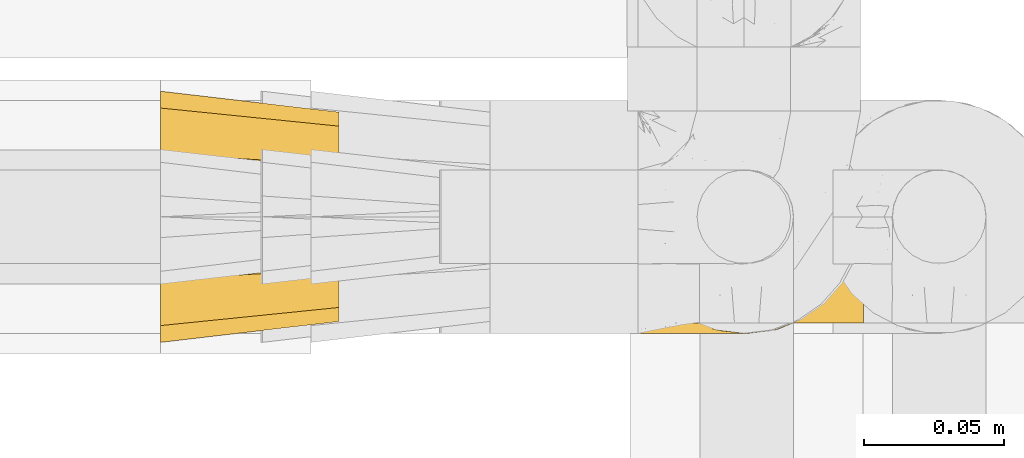
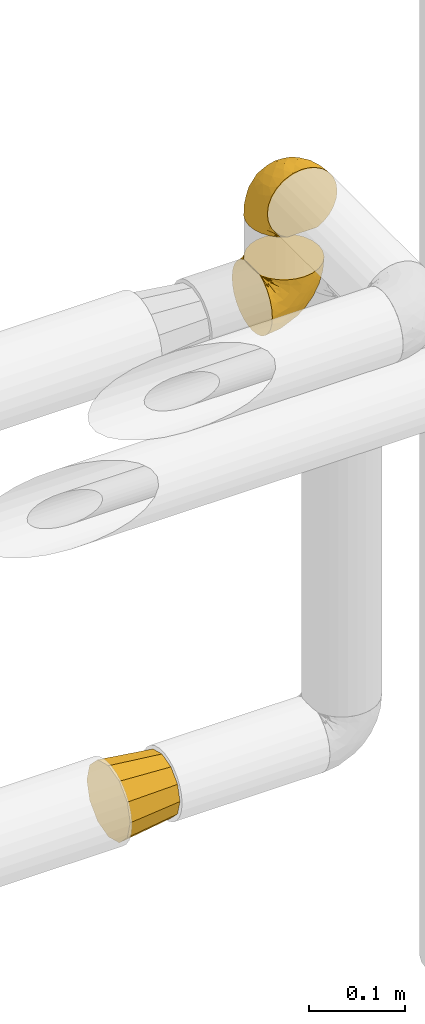
# One storey, part 458 of 827: 3 coverings.
"""IFC2X3 building model written with IfcOpenShell, lengths in millimetres."""

from ifc_helpers import new_model, entity, si_unit, converted_unit, derived_unit, direction, frame, origin, place, context, subcontext, project, spatial, faceted_brep, element, save


model = new_model("IFC2X3")

# Units and contexts
model_context = context("Model", 3, precision=0.01, world=origin(), true_north=direction((6.12303176911189e-17, 1.0)))
body_context = subcontext(model_context, "Body", "Model", "MODEL_VIEW")
ifc_project = project(units=[si_unit("LENGTHUNIT", "METRE", prefix="MILLI"), si_unit("AREAUNIT", "SQUARE_METRE"), si_unit("VOLUMEUNIT", "CUBIC_METRE"), converted_unit("PLANEANGLEUNIT", "DEGREE", entity("IfcRatioMeasure", 0.0174532925199433), si_unit("PLANEANGLEUNIT", "RADIAN"), dimensions=[0, 0, 0, 0, 0, 0, 0]), si_unit("MASSUNIT", "GRAM", prefix="KILO"), derived_unit("MASSDENSITYUNIT", [(si_unit("MASSUNIT", "GRAM", prefix="KILO"), 1), (si_unit("LENGTHUNIT", "METRE"), -3)]), derived_unit("MOMENTOFINERTIAUNIT", [(si_unit("LENGTHUNIT", "METRE"), 4)]), si_unit("TIMEUNIT", "SECOND"), si_unit("FREQUENCYUNIT", "HERTZ"), si_unit("THERMODYNAMICTEMPERATUREUNIT", "DEGREE_CELSIUS"), derived_unit("THERMALTRANSMITTANCEUNIT", [(si_unit("MASSUNIT", "GRAM", prefix="KILO"), 1), (si_unit("THERMODYNAMICTEMPERATUREUNIT", "KELVIN"), -1), (si_unit("TIMEUNIT", "SECOND"), -3)]), derived_unit("VOLUMETRICFLOWRATEUNIT", [(si_unit("LENGTHUNIT", "METRE"), 3), (si_unit("TIMEUNIT", "SECOND"), -1)]), derived_unit("MASSFLOWRATEUNIT", [(si_unit("MASSUNIT", "GRAM", prefix="KILO"), 1), (si_unit("TIMEUNIT", "SECOND"), -1)]), derived_unit("ROTATIONALFREQUENCYUNIT", [(si_unit("TIMEUNIT", "SECOND"), -1)]), si_unit("ELECTRICCURRENTUNIT", "AMPERE"), si_unit("ELECTRICVOLTAGEUNIT", "VOLT"), si_unit("POWERUNIT", "WATT"), si_unit("FORCEUNIT", "NEWTON", prefix="KILO"), si_unit("ILLUMINANCEUNIT", "LUX"), si_unit("LUMINOUSFLUXUNIT", "LUMEN"), si_unit("LUMINOUSINTENSITYUNIT", "CANDELA"), derived_unit("USERDEFINED", [(si_unit("MASSUNIT", "GRAM", prefix="KILO"), -1), (si_unit("LENGTHUNIT", "METRE"), -2), (si_unit("TIMEUNIT", "SECOND"), 3), (si_unit("LUMINOUSFLUXUNIT", "LUMEN"), 1)]), derived_unit("LINEARVELOCITYUNIT", [(si_unit("LENGTHUNIT", "METRE"), 1), (si_unit("TIMEUNIT", "SECOND"), -1)]), si_unit("PRESSUREUNIT", "PASCAL"), derived_unit("USERDEFINED", [(si_unit("LENGTHUNIT", "METRE"), -2), (si_unit("MASSUNIT", "GRAM", prefix="KILO"), 1), (si_unit("TIMEUNIT", "SECOND"), -2)]), derived_unit("LINEARFORCEUNIT", [(si_unit("MASSUNIT", "GRAM", prefix="KILO"), 1), (si_unit("LENGTHUNIT", "METRE"), 1), (si_unit("TIMEUNIT", "SECOND"), -2), (si_unit("LENGTHUNIT", "METRE"), -1)]), derived_unit("PLANARFORCEUNIT", [(si_unit("MASSUNIT", "GRAM", prefix="KILO"), 1), (si_unit("LENGTHUNIT", "METRE"), 1), (si_unit("TIMEUNIT", "SECOND"), -2), (si_unit("LENGTHUNIT", "METRE"), -2)])], contexts=[model_context])

# Site, building, storey
site_placement = place(None, origin())
site = spatial("IfcSite", under=ifc_project, at=site_placement, CompositionType="ELEMENT")
building_placement = place(site_placement, origin())
building = spatial("IfcBuilding", under=site, at=building_placement, CompositionType="ELEMENT")
storey_placement = place(building_placement, frame((0.0, 0.0, 28200.0)))
storey = spatial("IfcBuildingStorey", under=building, at=storey_placement, Name="08", CompositionType="ELEMENT", Elevation=28200.0)

# Coverings
covering_1_placement = place(storey_placement, frame((56354.23, 17453.4, 745.9)))
element("IfcCovering", 1, at=covering_1_placement, inside=storey, Name=":ADSK_", ObjectType=":ADSK_", PredefinedType="INSULATION", context=body_context, shape_type="Brep", body=[
    faceted_brep([(64.0, 9.1, 46.6), (64.0, 11.61, 37.22), (64.0, 14.12, 27.85), (64.0, 20.98, 20.98), (64.0, 27.85, 14.12), (64.0, 37.22, 11.61), (64.0, 46.6, 9.1), (64.0, 55.97, 11.61), (64.0, 65.35, 14.12), (64.0, 72.21, 20.98), (64.0, 79.07, 27.85), (64.0, 81.58, 37.22), (64.0, 84.1, 46.6), (64.0, 81.58, 55.97), (64.0, 79.07, 65.35), (64.0, 72.21, 72.21), (64.0, 65.35, 79.07), (64.0, 55.97, 81.58), (64.0, 46.6, 84.1), (64.0, 37.22, 81.58), (64.0, 27.85, 79.07), (64.0, 20.98, 72.21), (64.0, 14.12, 65.35), (64.0, 11.61, 55.97), (0.0, 77.33, 77.33), (0.0, 85.57, 69.1), (0.0, 88.1, 59.65), (0.0, 91.6, 46.6), (0.0, 88.1, 33.54), (0.0, 85.57, 24.1), (0.0, 77.33, 15.86), (0.0, 69.1, 7.62), (0.0, 59.65, 5.09), (0.0, 46.6, 1.6), (0.0, 33.54, 5.09), (0.0, 24.1, 7.62), (0.0, 15.86, 15.86), (0.0, 7.62, 24.1), (0.0, 5.09, 33.54), (0.0, 1.6, 46.6), (0.0, 5.09, 59.65), (0.0, 7.62, 69.1), (0.0, 15.86, 77.33), (0.0, 24.1, 85.57), (0.0, 33.54, 88.1), (0.0, 46.6, 91.6), (0.0, 59.65, 88.1), (0.0, 69.1, 85.57)], [[[0, 1, 2, 3, 4, 5, 6, 7, 8, 9, 10, 11, 12, 13, 14, 15, 16, 17, 18, 19, 20, 21, 22, 23]], [[24, 25, 26, 27, 28, 29, 30, 31, 32, 33, 34, 35, 36, 37, 38, 39, 40, 41, 42, 43, 44, 45, 46, 47]], [[4, 35, 34, 33, 6, 5]], [[37, 36, 35, 4, 3, 2]], [[1, 0, 39, 38, 37, 2]], [[10, 29, 28, 27, 12, 11]], [[31, 30, 29, 10, 9, 8]], [[7, 6, 33, 32, 31, 8]], [[16, 47, 46, 45, 18, 17]], [[25, 24, 47, 16, 15, 14]], [[13, 12, 27, 26, 25, 14]], [[22, 41, 40, 39, 0, 23]], [[43, 42, 41, 22, 21, 20]], [[19, 18, 45, 44, 43, 20]]]),
])
covering_2_placement = place(storey_placement, frame((56520.78, 17460.4, 1460.4)))
element("IfcCovering", 2, at=covering_2_placement, inside=storey, Name=":ADSK_", ObjectType=":ADSK_", PredefinedType="INSULATION", context=body_context, shape_type="Brep", body=[
    faceted_brep([(5.74, 57.76, 1.6), (10.73, 65.69, 1.6), (17.36, 72.32, 1.6), (25.29, 77.3, 1.6), (34.14, 80.4, 1.6), (43.45, 81.45, 1.6), (52.76, 80.39, 1.6), (61.61, 77.3, 1.6), (69.54, 72.31, 1.6), (76.17, 65.68, 1.6), (81.15, 57.75, 1.6), (84.25, 48.9, 1.6), (85.3, 39.6, 1.6), (84.23, 30.22, 1.6), (81.1, 21.33, 1.6), (76.06, 13.37, 1.6), (69.36, 6.73, 1.6), (61.36, 1.77, 1.6), (60.44, 1.77, 1.6), (59.52, 1.77, 1.6), (58.72, 1.77, 1.6), (57.4, 1.77, 1.6), (56.08, 1.77, 1.6), (54.76, 1.77, 1.6), (53.44, 1.77, 1.6), (52.12, 1.77, 1.6), (50.8, 1.77, 1.6), (49.47, 1.77, 1.6), (48.15, 1.77, 1.6), (46.83, 1.77, 1.6), (45.51, 1.77, 1.6), (44.19, 1.77, 1.6), (42.87, 1.77, 1.6), (41.55, 1.77, 1.6), (40.23, 1.77, 1.6), (39.31, 1.77, 1.6), (38.39, 1.77, 1.6), (37.48, 1.77, 1.6), (36.56, 1.77, 1.6), (35.64, 1.77, 1.6), (34.72, 1.77, 1.6), (33.8, 1.77, 1.6), (32.88, 1.77, 1.6), (31.96, 1.77, 1.6), (31.05, 1.77, 1.6), (30.13, 1.77, 1.6), (29.21, 1.77, 1.6), (28.29, 1.77, 1.6), (27.37, 1.77, 1.6), (26.45, 1.77, 1.6), (25.53, 1.77, 1.6), (17.52, 6.74, 1.6), (10.82, 13.38, 1.6), (5.78, 21.35, 1.6), (2.65, 30.24, 1.6), (1.6, 39.6, 1.6), (2.65, 48.91, 1.6), (61.36, 1.6, 1.77), (69.37, 1.6, 6.74), (76.06, 1.6, 13.37), (81.1, 1.6, 21.34), (84.23, 1.6, 30.23), (85.3, 1.6, 39.6), (83.87, 1.6, 50.43), (79.69, 1.6, 60.52), (73.04, 1.6, 69.19), (64.37, 1.6, 75.84), (54.28, 1.6, 80.02), (43.45, 1.6, 81.45), (32.61, 1.6, 80.02), (22.52, 1.6, 75.84), (13.85, 1.6, 69.19), (7.2, 1.6, 60.52), (3.02, 1.6, 50.43), (1.6, 1.6, 39.6), (2.66, 1.6, 30.23), (5.79, 1.6, 21.34), (10.83, 1.6, 13.37), (17.52, 1.6, 6.74), (25.53, 1.6, 1.77), (26.45, 1.6, 1.77), (27.77, 1.6, 1.77), (28.89, 1.6, 1.77), (30.01, 1.6, 1.77), (31.13, 1.6, 1.77), (32.25, 1.6, 1.77), (33.37, 1.6, 1.77), (34.49, 1.6, 1.77), (35.61, 1.6, 1.77), (36.73, 1.6, 1.77), (37.85, 1.6, 1.77), (38.97, 1.6, 1.77), (40.09, 1.6, 1.77), (41.21, 1.6, 1.77), (42.33, 1.6, 1.77), (43.45, 1.6, 1.77), (44.77, 1.6, 1.77), (46.09, 1.6, 1.77), (47.41, 1.6, 1.77), (48.73, 1.6, 1.77), (50.05, 1.6, 1.77), (51.37, 1.6, 1.77), (52.69, 1.6, 1.77), (54.01, 1.6, 1.77), (54.93, 1.6, 1.77), (55.85, 1.6, 1.77), (56.76, 1.6, 1.77), (57.68, 1.6, 1.77), (58.6, 1.6, 1.77), (59.52, 1.6, 1.77), (60.44, 1.6, 1.77), (32.81, 1.71, 1.73), (31.73, 1.73, 1.72), (50.71, 1.71, 1.73), (51.76, 1.72, 1.72), (42.89, 1.71, 1.73), (41.81, 1.72, 1.73), (25.53, 1.72, 1.72), (26.91, 1.72, 1.72), (40.71, 1.72, 1.72), (60.15, 1.72, 1.72), (39.53, 1.72, 1.72), (57.22, 1.72, 1.73), (58.17, 1.7, 1.74), (47.12, 1.72, 1.72), (33.93, 1.73, 1.71), (35.05, 1.72, 1.73), (46.09, 1.73, 1.71), (45.02, 1.73, 1.72), (43.95, 1.72, 1.73), (59.12, 1.72, 1.72), (38.49, 1.71, 1.73), (49.68, 1.72, 1.72), (53.35, 1.71, 1.73), (54.4, 1.72, 1.72), (56.2, 1.72, 1.72), (36.2, 1.72, 1.72), (37.29, 1.73, 1.71), (30.57, 1.72, 1.72), (29.45, 1.71, 1.73), (28.01, 1.73, 1.71), (61.36, 1.72, 1.72), (25.53, 1.74, 1.68), (25.53, 1.75, 1.64), (61.36, 1.75, 1.64), (61.36, 1.74, 1.68), (25.53, 1.64, 1.75), (25.53, 1.68, 1.74), (61.36, 1.68, 1.74), (61.36, 1.64, 1.75), (55.3, 1.74, 1.7), (48.18, 1.71, 1.73), (82.92, 8.98, 24.54), (85.3, 37.05, 11.1), (82.92, 24.69, 8.47), (78.8, 15.28, 9.11), (78.8, 16.86, 4.86), (70.46, 6.58, 5.0), (71.16, 5.71, 6.81), (85.3, 11.1, 37.05), (76.1, 10.79, 9.03), (72.9, 4.13, 9.47), (78.81, 6.62, 16.39), (72.89, 9.52, 3.95), (74.06, 6.14, 9.9), (83.71, 17.79, 22.7), (85.3, 20.6, 34.5), (85.3, 8.73, 37.68), (83.61, 23.66, 15.82), (85.3, 34.5, 20.6), (80.61, 15.32, 14.37), (85.3, 27.55, 27.55), (67.83, 3.31, 5.2), (78.81, 9.81, 14.88), (85.3, 37.68, 8.73), (54.78, 67.23, 44.27), (57.27, 76.64, 20.94), (43.45, 75.37, 32.15), (84.45, 14.58, 46.13), (84.39, 23.71, 42.67), (77.16, 34.34, 55.18), (68.92, 29.1, 67.27), (76.65, 18.02, 62.91), (82.11, 22.27, 51.5), (82.11, 10.97, 54.79), (78.88, 56.79, 25.78), (78.88, 60.76, 13.05), (73.04, 67.04, 18.46), (84.47, 36.11, 32.4), (65.72, 68.85, 31.07), (51.16, 24.58, 77.32), (59.46, 21.54, 75.62), (43.45, 78.4, 16.9), (68.92, 14.11, 71.69), (51.18, 53.42, 61.4), (57.42, 58.19, 54.47), (83.48, 44.49, 27.66), (82.95, 51.77, 14.53), (65.72, 73.69, 15.56), (78.97, 45.89, 42.26), (82.64, 35.97, 41.51), (75.14, 56.55, 36.93), (68.58, 60.03, 42.72), (61.95, 63.64, 44.68), (58.11, 34.98, 71.2), (51.07, 40.58, 70.48), (43.45, 32.15, 75.37), (58.51, 47.26, 63.65), (43.45, 58.06, 58.06), (43.45, 66.71, 45.11), (43.45, 16.9, 78.4), (65.68, 52.08, 54.95), (70.41, 41.21, 59.31), (73.04, 49.76, 49.01), (43.45, 45.11, 66.71), (4.78, 15.65, 53.75), (35.48, 24.57, 77.27), (29.45, 50.54, 61.6), (32.11, 67.25, 44.24), (13.86, 67.06, 18.46), (21.19, 73.7, 15.55), (10.24, 26.13, 60.14), (17.97, 19.54, 70.5), (18.88, 38.96, 63.0), (8.01, 56.8, 25.78), (8.01, 60.77, 13.05), (3.95, 51.78, 14.53), (22.45, 59.09, 48.5), (2.4, 19.25, 44.23), (1.6, 20.6, 34.5), (1.6, 11.1, 37.05), (1.6, 37.68, 8.73), (29.05, 15.21, 77.68), (10.24, 12.76, 64.08), (35.7, 40.93, 70.25), (29.63, 76.65, 20.93), (8.75, 39.5, 49.9), (4.54, 25.01, 49.6), (21.19, 68.86, 31.06), (2.28, 26.7, 39.62), (2.53, 34.95, 34.42), (1.6, 34.5, 20.6), (1.6, 27.55, 27.55), (13.86, 61.27, 33.36), (3.41, 44.5, 27.68), (1.6, 37.05, 11.1), (2.35, 10.25, 46.67), (13.86, 49.78, 49.0), (7.35, 47.51, 38.94), (27.43, 29.38, 73.05), (13.39, 40.01, 56.63), (4.32, 33.36, 43.85), (3.97, 8.98, 24.54), (3.27, 23.67, 15.82), (3.97, 24.71, 8.47), (8.08, 15.29, 9.12), (13.99, 4.13, 9.47), (12.83, 6.14, 9.91), (8.08, 4.96, 16.85), (8.08, 9.81, 14.88), (19.06, 3.31, 5.2), (15.74, 5.7, 6.81), (13.98, 9.53, 3.96), (16.42, 6.59, 5.0), (8.08, 16.63, 5.86), (6.27, 15.34, 14.38), (10.78, 10.8, 9.04), (3.18, 17.79, 22.7)], [[[0, 1, 2, 3, 4, 5, 6, 7, 8, 9, 10, 11, 12, 13, 14, 15, 16, 17, 18, 19, 20, 21, 22, 23, 24, 25, 26, 27, 28, 29, 30, 31, 32, 33, 34, 35, 36, 37, 38, 39, 40, 41, 42, 43, 44, 45, 46, 47, 48, 49, 50, 51, 52, 53, 54, 55, 56]], [[57, 58, 59, 60, 61, 62, 63, 64, 65, 66, 67, 68, 69, 70, 71, 72, 73, 74, 75, 76, 77, 78, 79, 80, 81, 82, 83, 84, 85, 86, 87, 88, 89, 90, 91, 92, 93, 94, 95, 96, 97, 98, 99, 100, 101, 102, 103, 104, 105, 106, 107, 108, 109, 110]], [[111, 85, 112]], [[113, 26, 114]], [[114, 102, 101]], [[115, 94, 116]], [[80, 117, 118]], [[33, 116, 119]], [[117, 49, 118]], [[19, 18, 120]], [[119, 121, 34]], [[122, 21, 123]], [[98, 97, 124]], [[87, 125, 126]], [[116, 93, 119]], [[127, 97, 128]], [[32, 129, 115]], [[19, 120, 130]], [[121, 91, 131]], [[95, 115, 129]], [[115, 116, 32]], [[118, 49, 48]], [[113, 100, 132]], [[133, 114, 25]], [[24, 134, 133]], [[135, 22, 122]], [[136, 137, 89]], [[85, 84, 112]], [[138, 83, 139]], [[130, 20, 19]], [[118, 48, 140]], [[82, 140, 139]], [[123, 21, 20]], [[141, 120, 18]], [[139, 83, 82]], [[130, 108, 123]], [[49, 117, 142, 143, 50]], [[18, 17, 144, 145, 141]], [[80, 79, 146, 147, 117]], [[110, 141, 148, 149, 57]], [[103, 133, 134]], [[106, 135, 122]], [[118, 81, 80]], [[81, 118, 140]], [[120, 110, 109]], [[47, 46, 140, 48]], [[82, 81, 140]], [[44, 112, 138]], [[94, 115, 95]], [[46, 139, 140]], [[46, 45, 139]], [[139, 45, 138]], [[138, 112, 84]], [[86, 85, 111]], [[112, 43, 111]], [[84, 83, 138]], [[107, 122, 123]], [[106, 122, 107]], [[21, 122, 22]], [[124, 29, 28]], [[33, 32, 116]], [[128, 129, 31]], [[32, 31, 129]], [[34, 33, 119]], [[116, 94, 93]], [[129, 96, 95]], [[96, 129, 128]], [[41, 40, 125, 42]], [[119, 92, 121]], [[36, 35, 131, 37]], [[137, 131, 90]], [[121, 131, 35]], [[91, 121, 92]], [[119, 93, 92]], [[136, 126, 39]], [[125, 87, 86]], [[42, 125, 111]], [[86, 111, 125]], [[150, 23, 22]], [[130, 109, 108]], [[130, 123, 20]], [[108, 107, 123]], [[137, 37, 131]], [[136, 38, 137]], [[90, 89, 137]], [[131, 91, 90]], [[124, 151, 98]], [[40, 39, 126]], [[88, 126, 136]], [[87, 126, 88]], [[136, 89, 88]], [[40, 126, 125]], [[39, 38, 136]], [[96, 128, 97]], [[30, 128, 31]], [[29, 124, 127]], [[127, 128, 30]], [[151, 124, 28]], [[127, 30, 29]], [[127, 124, 97]], [[151, 99, 98]], [[45, 44, 138]], [[26, 113, 132]], [[113, 101, 100]], [[132, 151, 27]], [[27, 26, 132]], [[26, 25, 114]], [[101, 113, 114]], [[102, 133, 103]], [[133, 102, 114]], [[28, 27, 151]], [[132, 100, 99]], [[23, 134, 24]], [[25, 24, 133]], [[134, 23, 150]], [[135, 105, 150]], [[150, 105, 104]], [[104, 103, 134]], [[130, 120, 109]], [[110, 120, 141]], [[42, 111, 43]], [[112, 44, 43]], [[105, 135, 106]], [[134, 150, 104]], [[135, 150, 22]], [[35, 34, 121]], [[137, 38, 37]], [[99, 151, 132]], [[60, 152, 61]], [[13, 153, 154]], [[155, 156, 154]], [[157, 158, 141]], [[159, 61, 152]], [[160, 157, 155]], [[161, 162, 59]], [[59, 162, 60]], [[144, 16, 163]], [[59, 58, 161]], [[162, 161, 164]], [[157, 163, 155]], [[163, 16, 15]], [[58, 149, 161]], [[152, 165, 166]], [[157, 144, 163]], [[61, 159, 167, 62]], [[156, 14, 154]], [[163, 156, 155]], [[155, 154, 168]], [[168, 154, 169]], [[155, 170, 160]], [[58, 57, 149]], [[144, 17, 16]], [[156, 15, 14]], [[171, 165, 168]], [[158, 164, 172]], [[14, 13, 154]], [[157, 141, 145, 144]], [[173, 164, 158]], [[173, 160, 170]], [[171, 166, 165]], [[168, 165, 170]], [[168, 169, 171]], [[152, 173, 165]], [[170, 155, 168]], [[165, 173, 170]], [[160, 173, 158]], [[172, 149, 148]], [[148, 141, 158]], [[158, 157, 160]], [[152, 166, 159]], [[173, 152, 162]], [[60, 162, 152]], [[13, 12, 174, 153]], [[153, 169, 154]], [[15, 156, 163]], [[162, 164, 173]], [[172, 164, 161]], [[149, 172, 161]], [[158, 172, 148]], [[175, 176, 177]], [[178, 166, 179]], [[180, 181, 182]], [[183, 184, 178]], [[185, 186, 187]], [[171, 188, 179]], [[174, 12, 11]], [[189, 176, 175]], [[190, 67, 191]], [[176, 6, 192]], [[193, 66, 65]], [[64, 184, 182]], [[64, 182, 65]], [[66, 193, 191]], [[184, 64, 63]], [[175, 194, 195]], [[196, 169, 197]], [[174, 11, 197]], [[8, 7, 198]], [[187, 9, 8]], [[197, 169, 153, 174]], [[197, 11, 10]], [[186, 197, 10]], [[199, 180, 200]], [[197, 185, 196]], [[201, 189, 202]], [[201, 187, 189]], [[195, 203, 175]], [[191, 204, 190]], [[176, 7, 6]], [[177, 176, 192]], [[189, 198, 176]], [[66, 191, 67]], [[198, 187, 8]], [[205, 206, 190]], [[9, 186, 10]], [[181, 207, 204]], [[208, 175, 177, 209]], [[67, 190, 210]], [[211, 212, 213]], [[190, 204, 205]], [[180, 182, 183]], [[193, 182, 181]], [[63, 62, 167]], [[196, 185, 199]], [[196, 200, 188]], [[6, 5, 192]], [[176, 198, 7]], [[187, 198, 189]], [[187, 186, 9]], [[197, 186, 185]], [[200, 180, 183]], [[180, 213, 212]], [[179, 183, 178]], [[185, 201, 199]], [[210, 190, 206]], [[210, 68, 67]], [[205, 204, 207]], [[194, 205, 207]], [[194, 214, 205]], [[195, 194, 207]], [[208, 194, 175]], [[207, 211, 195]], [[202, 203, 211]], [[212, 207, 181]], [[202, 211, 213]], [[201, 202, 213]], [[189, 175, 203]], [[199, 201, 213]], [[187, 201, 185]], [[180, 199, 213]], [[196, 199, 200]], [[211, 203, 195]], [[189, 203, 202]], [[207, 212, 211]], [[180, 212, 181]], [[214, 194, 208]], [[214, 206, 205]], [[196, 188, 169]], [[181, 204, 191]], [[182, 193, 65]], [[191, 193, 181]], [[178, 63, 167]], [[182, 184, 183]], [[63, 178, 184]], [[178, 167, 159, 166]], [[171, 179, 166]], [[200, 183, 179]], [[179, 188, 200]], [[169, 188, 171]], [[72, 215, 73]], [[206, 216, 210]], [[217, 208, 218]], [[216, 69, 210]], [[219, 220, 2]], [[221, 222, 223]], [[224, 225, 226]], [[227, 223, 217]], [[228, 229, 230]], [[56, 231, 226]], [[232, 222, 70]], [[56, 55, 231]], [[71, 233, 72]], [[72, 233, 215]], [[0, 56, 226]], [[208, 217, 234]], [[218, 177, 235]], [[221, 236, 237]], [[238, 220, 219]], [[1, 219, 2]], [[69, 216, 232]], [[235, 3, 220]], [[235, 192, 4]], [[1, 0, 225]], [[228, 239, 229]], [[240, 241, 242]], [[243, 238, 219]], [[224, 226, 244]], [[226, 241, 244]], [[3, 235, 4]], [[70, 222, 71]], [[225, 219, 1]], [[218, 235, 238]], [[243, 219, 224]], [[218, 227, 217]], [[3, 2, 220]], [[218, 208, 209, 177]], [[226, 231, 245, 241]], [[215, 228, 246]], [[247, 248, 236]], [[248, 224, 244]], [[223, 222, 249]], [[233, 222, 221]], [[242, 239, 240]], [[248, 247, 243]], [[217, 223, 249]], [[250, 247, 236]], [[216, 234, 249]], [[218, 238, 227]], [[192, 235, 177]], [[192, 5, 4]], [[73, 246, 74]], [[235, 220, 238]], [[226, 225, 0]], [[219, 225, 224]], [[240, 248, 244]], [[239, 242, 229]], [[236, 248, 251]], [[69, 68, 210]], [[234, 216, 206]], [[216, 249, 232]], [[234, 206, 214, 208]], [[249, 234, 217]], [[222, 232, 249]], [[70, 69, 232]], [[246, 228, 230]], [[237, 228, 215]], [[243, 227, 238]], [[223, 227, 247]], [[74, 246, 230]], [[215, 246, 73]], [[248, 243, 224]], [[227, 243, 247]], [[237, 236, 251]], [[250, 221, 223]], [[222, 233, 71]], [[215, 233, 221]], [[221, 237, 215]], [[239, 237, 251]], [[237, 239, 228]], [[239, 251, 240]], [[248, 240, 251]], [[241, 240, 244]], [[221, 250, 236]], [[223, 247, 250]], [[75, 230, 252]], [[253, 254, 255]], [[146, 78, 256]], [[257, 258, 259]], [[260, 256, 257]], [[260, 261, 147]], [[76, 75, 252]], [[51, 143, 262]], [[263, 143, 142, 117]], [[256, 78, 77]], [[252, 258, 76]], [[253, 241, 254]], [[254, 245, 54]], [[258, 256, 77]], [[53, 52, 264]], [[255, 265, 253]], [[254, 264, 255]], [[255, 264, 262]], [[76, 258, 77]], [[265, 255, 266]], [[255, 262, 263]], [[51, 50, 143]], [[54, 245, 231, 55]], [[51, 262, 52]], [[253, 267, 242]], [[254, 54, 53]], [[266, 259, 265]], [[146, 79, 78]], [[263, 117, 261]], [[146, 256, 260]], [[257, 259, 261]], [[267, 253, 265]], [[229, 267, 252]], [[242, 267, 229]], [[242, 241, 253]], [[252, 267, 259]], [[255, 263, 266]], [[259, 267, 265]], [[261, 117, 147]], [[263, 261, 266]], [[259, 266, 261]], [[230, 75, 74]], [[230, 229, 252]], [[259, 258, 252]], [[254, 241, 245]], [[53, 264, 254]], [[52, 262, 264]], [[143, 263, 262]], [[258, 257, 256]], [[261, 260, 257]], [[146, 260, 147]]]),
])
covering_3_placement = place(storey_placement, frame((56524.63, 17456.55, 1326.55)))
element("IfcCovering", 3, at=covering_3_placement, inside=storey, Name=":ADSK_", ObjectType=":ADSK_", PredefinedType="INSULATION", context=body_context, shape_type="Brep", body=[
    faceted_brep([(1.6, 81.15, 25.28), (1.6, 76.16, 17.35), (1.6, 69.53, 10.72), (1.6, 61.6, 5.74), (1.6, 52.75, 2.64), (1.6, 43.45, 1.6), (1.6, 34.13, 2.65), (1.6, 25.28, 5.74), (1.6, 17.35, 10.73), (1.6, 10.72, 17.36), (1.6, 5.74, 25.29), (1.6, 2.64, 34.14), (1.6, 1.6, 43.45), (1.6, 2.66, 52.82), (1.6, 5.79, 61.71), (1.6, 10.83, 69.67), (1.6, 17.53, 76.31), (1.6, 25.53, 81.27), (1.6, 26.45, 81.27), (1.6, 27.37, 81.27), (1.6, 28.17, 81.27), (1.6, 29.49, 81.27), (1.6, 30.81, 81.27), (1.6, 32.13, 81.27), (1.6, 33.45, 81.27), (1.6, 34.78, 81.27), (1.6, 36.1, 81.27), (1.6, 37.42, 81.27), (1.6, 38.74, 81.27), (1.6, 40.06, 81.27), (1.6, 41.38, 81.27), (1.6, 42.7, 81.27), (1.6, 44.02, 81.27), (1.6, 45.34, 81.27), (1.6, 46.66, 81.27), (1.6, 47.58, 81.27), (1.6, 48.5, 81.27), (1.6, 49.41, 81.27), (1.6, 50.33, 81.27), (1.6, 51.25, 81.27), (1.6, 52.17, 81.27), (1.6, 53.09, 81.27), (1.6, 54.01, 81.27), (1.6, 54.93, 81.27), (1.6, 55.85, 81.27), (1.6, 56.76, 81.27), (1.6, 57.68, 81.27), (1.6, 58.6, 81.27), (1.6, 59.52, 81.27), (1.6, 60.44, 81.27), (1.6, 61.36, 81.27), (1.6, 69.37, 76.3), (1.6, 76.07, 69.66), (1.6, 81.11, 61.69), (1.6, 84.24, 52.8), (1.6, 85.3, 43.45), (1.6, 84.24, 34.13), (6.74, 17.52, 81.45), (13.37, 10.83, 81.45), (21.34, 5.79, 81.45), (30.23, 2.66, 81.45), (39.6, 1.6, 81.45), (50.43, 3.02, 81.45), (60.52, 7.2, 81.45), (69.19, 13.85, 81.45), (75.84, 22.52, 81.45), (80.02, 32.61, 81.45), (81.45, 43.45, 81.45), (80.02, 54.28, 81.45), (75.84, 64.37, 81.45), (69.19, 73.04, 81.45), (60.52, 79.69, 81.45), (50.43, 83.87, 81.45), (39.6, 85.3, 81.45), (30.23, 84.23, 81.45), (21.34, 81.1, 81.45), (13.37, 76.06, 81.45), (6.74, 69.37, 81.45), (1.77, 61.36, 81.45), (1.77, 60.44, 81.45), (1.77, 59.12, 81.45), (1.77, 58.0, 81.45), (1.77, 56.88, 81.45), (1.77, 55.76, 81.45), (1.77, 54.64, 81.45), (1.77, 53.52, 81.45), (1.77, 52.4, 81.45), (1.77, 51.28, 81.45), (1.77, 50.16, 81.45), (1.77, 49.04, 81.45), (1.77, 47.92, 81.45), (1.77, 46.8, 81.45), (1.77, 45.68, 81.45), (1.77, 44.56, 81.45), (1.77, 43.45, 81.45), (1.77, 42.12, 81.45), (1.77, 40.8, 81.45), (1.77, 39.48, 81.45), (1.77, 38.16, 81.45), (1.77, 36.84, 81.45), (1.77, 35.52, 81.45), (1.77, 34.2, 81.45), (1.77, 32.88, 81.45), (1.77, 31.96, 81.45), (1.77, 31.05, 81.45), (1.77, 30.13, 81.45), (1.77, 29.21, 81.45), (1.77, 28.29, 81.45), (1.77, 27.37, 81.45), (1.77, 26.45, 81.45), (1.77, 25.53, 81.45), (1.73, 54.08, 81.33), (1.72, 55.16, 81.32), (1.73, 36.18, 81.33), (1.72, 35.13, 81.32), (1.73, 44.01, 81.33), (1.73, 45.08, 81.32), (1.72, 61.36, 81.32), (1.72, 59.98, 81.32), (1.72, 46.18, 81.32), (1.72, 26.74, 81.32), (1.72, 47.36, 81.32), (1.73, 29.67, 81.32), (1.74, 28.72, 81.34), (1.72, 39.77, 81.32), (1.71, 52.96, 81.31), (1.73, 51.84, 81.33), (1.71, 40.8, 81.31), (1.72, 41.87, 81.32), (1.73, 42.94, 81.33), (1.72, 27.77, 81.32), (1.73, 48.4, 81.33), (1.72, 37.21, 81.32), (1.73, 33.54, 81.33), (1.72, 32.49, 81.32), (1.72, 30.69, 81.32), (1.72, 50.69, 81.32), (1.71, 49.6, 81.31), (1.72, 56.32, 81.32), (1.73, 57.44, 81.33), (1.71, 58.88, 81.31), (1.72, 25.53, 81.32), (1.68, 61.36, 81.3), (1.64, 61.36, 81.29), (1.75, 61.36, 81.4), (1.74, 61.36, 81.36), (1.74, 25.53, 81.36), (1.75, 25.53, 81.4), (1.64, 25.53, 81.29), (1.68, 25.53, 81.3), (1.7, 31.59, 81.3), (1.73, 38.71, 81.33), (24.54, 3.97, 74.06), (11.1, 1.6, 45.99), (8.47, 3.97, 58.35), (9.11, 8.09, 67.76), (4.86, 8.09, 66.18), (5.0, 16.43, 76.46), (6.81, 15.73, 77.33), (37.05, 1.6, 71.95), (9.03, 10.79, 72.25), (9.47, 13.99, 78.91), (16.39, 8.08, 76.42), (3.95, 14.0, 73.52), (9.9, 12.83, 76.9), (22.7, 3.18, 65.25), (34.5, 1.6, 62.45), (37.68, 1.6, 74.31), (15.82, 3.28, 59.38), (20.6, 1.6, 48.54), (14.37, 6.28, 67.72), (27.55, 1.6, 55.49), (5.2, 19.06, 79.73), (14.88, 8.08, 73.23), (8.73, 1.6, 45.36), (44.27, 32.11, 15.81), (20.94, 29.62, 6.4), (32.15, 43.45, 7.67), (46.13, 2.45, 68.46), (42.67, 2.5, 59.33), (55.18, 9.73, 48.7), (67.27, 17.97, 53.94), (62.91, 10.24, 65.02), (51.5, 4.78, 60.77), (54.79, 4.78, 72.07), (25.78, 8.01, 26.25), (13.05, 8.01, 22.29), (18.46, 13.85, 16.0), (32.4, 2.42, 46.93), (31.07, 21.17, 14.19), (77.32, 35.73, 58.46), (75.62, 27.43, 61.51), (16.9, 43.45, 4.64), (71.69, 17.97, 68.93), (61.4, 35.71, 29.62), (54.47, 29.47, 24.85), (27.66, 3.41, 38.55), (14.53, 3.94, 31.27), (15.56, 21.17, 9.35), (42.26, 7.92, 37.15), (41.51, 4.25, 47.07), (36.93, 11.75, 26.49), (42.72, 18.31, 23.01), (44.68, 24.94, 19.4), (71.2, 28.78, 48.06), (70.48, 35.82, 42.46), (75.37, 43.45, 50.89), (63.65, 28.38, 35.78), (58.06, 43.45, 24.98), (45.11, 43.45, 16.33), (78.4, 43.45, 66.14), (54.95, 21.21, 30.96), (59.31, 16.48, 41.83), (49.01, 13.85, 33.28), (66.71, 43.45, 37.94), (53.75, 82.11, 67.39), (77.27, 51.41, 58.47), (61.6, 57.45, 32.5), (44.24, 54.78, 15.79), (18.46, 73.03, 15.99), (15.55, 65.7, 9.34), (60.14, 76.65, 56.91), (70.5, 68.92, 63.5), (63.0, 68.01, 44.08), (25.78, 78.88, 26.24), (13.05, 78.88, 22.27), (14.53, 82.94, 31.26), (48.5, 64.44, 23.95), (44.23, 84.49, 63.79), (34.5, 85.3, 62.45), (37.05, 85.3, 71.95), (8.73, 85.3, 45.36), (77.68, 57.84, 67.83), (64.08, 76.65, 70.28), (70.25, 51.19, 42.11), (20.93, 57.26, 6.39), (49.9, 78.14, 43.54), (49.6, 82.35, 58.03), (31.06, 65.7, 14.18), (39.62, 84.61, 56.34), (34.42, 84.36, 48.09), (20.6, 85.3, 48.54), (27.55, 85.3, 55.49), (33.36, 73.03, 21.78), (27.68, 83.48, 38.54), (11.1, 85.3, 45.99), (46.67, 84.54, 72.79), (49.0, 73.03, 33.26), (38.94, 79.54, 35.53), (73.05, 59.46, 53.66), (56.63, 73.5, 43.03), (43.85, 82.57, 49.68), (24.54, 82.92, 74.06), (15.82, 83.62, 59.37), (8.47, 82.92, 58.34), (9.12, 78.81, 67.75), (9.47, 72.9, 78.91), (9.91, 74.06, 76.9), (16.85, 78.81, 78.08), (14.88, 78.81, 73.23), (5.2, 67.83, 79.73), (6.81, 71.15, 77.34), (3.96, 72.91, 73.51), (5.0, 70.47, 76.45), (5.86, 78.81, 66.41), (14.38, 80.62, 67.7), (9.04, 76.11, 72.24), (22.7, 83.71, 65.25)], [[[0, 1, 2, 3, 4, 5, 6, 7, 8, 9, 10, 11, 12, 13, 14, 15, 16, 17, 18, 19, 20, 21, 22, 23, 24, 25, 26, 27, 28, 29, 30, 31, 32, 33, 34, 35, 36, 37, 38, 39, 40, 41, 42, 43, 44, 45, 46, 47, 48, 49, 50, 51, 52, 53, 54, 55, 56]], [[57, 58, 59, 60, 61, 62, 63, 64, 65, 66, 67, 68, 69, 70, 71, 72, 73, 74, 75, 76, 77, 78, 79, 80, 81, 82, 83, 84, 85, 86, 87, 88, 89, 90, 91, 92, 93, 94, 95, 96, 97, 98, 99, 100, 101, 102, 103, 104, 105, 106, 107, 108, 109, 110]], [[111, 84, 112]], [[113, 26, 114]], [[114, 101, 100]], [[115, 93, 116]], [[79, 117, 118]], [[33, 116, 119]], [[117, 49, 118]], [[19, 18, 120]], [[119, 121, 34]], [[122, 21, 123]], [[97, 96, 124]], [[86, 125, 126]], [[116, 92, 119]], [[127, 96, 128]], [[32, 129, 115]], [[19, 120, 130]], [[121, 90, 131]], [[94, 115, 129]], [[115, 116, 32]], [[118, 49, 48]], [[113, 99, 132]], [[133, 114, 25]], [[24, 134, 133]], [[135, 22, 122]], [[136, 137, 88]], [[84, 83, 112]], [[138, 82, 139]], [[130, 20, 19]], [[118, 48, 140]], [[81, 140, 139]], [[123, 21, 20]], [[141, 120, 18]], [[139, 82, 81]], [[130, 107, 123]], [[49, 117, 142, 143]], [[79, 78, 144, 145, 117]], [[109, 141, 146, 147, 110]], [[102, 133, 134]], [[105, 135, 122]], [[118, 80, 79]], [[80, 118, 140]], [[18, 17, 148, 149, 141]], [[120, 109, 108]], [[47, 46, 140, 48]], [[81, 80, 140]], [[44, 112, 138]], [[93, 115, 94]], [[46, 139, 140]], [[46, 45, 139]], [[139, 45, 138]], [[138, 112, 83]], [[85, 84, 111]], [[112, 43, 111]], [[83, 82, 138]], [[106, 122, 123]], [[105, 122, 106]], [[21, 122, 22]], [[124, 29, 28]], [[33, 32, 116]], [[128, 129, 31]], [[32, 31, 129]], [[34, 33, 119]], [[116, 93, 92]], [[129, 95, 94]], [[95, 129, 128]], [[41, 40, 125, 42]], [[119, 91, 121]], [[36, 35, 131, 37]], [[137, 131, 89]], [[121, 131, 35]], [[90, 121, 91]], [[119, 92, 91]], [[136, 126, 39]], [[125, 86, 85]], [[42, 125, 111]], [[85, 111, 125]], [[150, 23, 22]], [[130, 108, 107]], [[130, 123, 20]], [[107, 106, 123]], [[137, 37, 131]], [[136, 38, 137]], [[89, 88, 137]], [[131, 90, 89]], [[124, 151, 97]], [[40, 39, 126]], [[87, 126, 136]], [[86, 126, 87]], [[136, 88, 87]], [[40, 126, 125]], [[39, 38, 136]], [[95, 128, 96]], [[30, 128, 31]], [[29, 124, 127]], [[127, 128, 30]], [[151, 124, 28]], [[127, 30, 29]], [[127, 124, 96]], [[151, 98, 97]], [[45, 44, 138]], [[26, 113, 132]], [[113, 100, 99]], [[132, 151, 27]], [[27, 26, 132]], [[26, 25, 114]], [[100, 113, 114]], [[101, 133, 102]], [[133, 101, 114]], [[28, 27, 151]], [[132, 99, 98]], [[23, 134, 24]], [[25, 24, 133]], [[134, 23, 150]], [[135, 104, 150]], [[150, 104, 103]], [[103, 102, 134]], [[130, 120, 108]], [[109, 120, 141]], [[42, 111, 43]], [[112, 44, 43]], [[104, 135, 105]], [[134, 150, 103]], [[135, 150, 22]], [[35, 34, 121]], [[137, 38, 37]], [[98, 151, 132]], [[59, 152, 60]], [[13, 153, 154]], [[155, 156, 154]], [[157, 158, 141]], [[159, 60, 152]], [[160, 157, 155]], [[161, 162, 58]], [[58, 162, 59]], [[148, 16, 163]], [[58, 57, 161]], [[162, 161, 164]], [[157, 163, 155]], [[163, 16, 15]], [[57, 147, 161]], [[152, 165, 166]], [[157, 148, 163]], [[60, 159, 167, 61]], [[156, 14, 154]], [[163, 156, 155]], [[155, 154, 168]], [[168, 154, 169]], [[155, 170, 160]], [[57, 110, 147]], [[148, 17, 16]], [[156, 15, 14]], [[171, 165, 168]], [[158, 164, 172]], [[14, 13, 154]], [[157, 141, 149, 148]], [[173, 164, 158]], [[173, 160, 170]], [[171, 166, 165]], [[168, 165, 170]], [[168, 169, 171]], [[152, 173, 165]], [[170, 155, 168]], [[165, 173, 170]], [[160, 173, 158]], [[172, 147, 146]], [[146, 141, 158]], [[158, 157, 160]], [[152, 166, 159]], [[173, 152, 162]], [[59, 162, 152]], [[13, 12, 174, 153]], [[153, 169, 154]], [[15, 156, 163]], [[162, 164, 173]], [[172, 164, 161]], [[147, 172, 161]], [[158, 172, 146]], [[175, 176, 177]], [[178, 166, 179]], [[180, 181, 182]], [[183, 184, 178]], [[185, 186, 187]], [[171, 188, 179]], [[174, 12, 11]], [[189, 176, 175]], [[190, 66, 191]], [[176, 6, 192]], [[193, 65, 64]], [[63, 184, 182]], [[63, 182, 64]], [[65, 193, 191]], [[184, 63, 62]], [[175, 194, 195]], [[196, 169, 197]], [[174, 11, 197]], [[8, 7, 198]], [[187, 9, 8]], [[197, 169, 153, 174]], [[197, 11, 10]], [[186, 197, 10]], [[199, 180, 200]], [[197, 185, 196]], [[201, 189, 202]], [[201, 187, 189]], [[195, 203, 175]], [[191, 204, 190]], [[176, 7, 6]], [[177, 176, 192]], [[189, 198, 176]], [[65, 191, 66]], [[198, 187, 8]], [[205, 206, 190]], [[9, 186, 10]], [[181, 207, 204]], [[208, 175, 177, 209]], [[66, 190, 210]], [[211, 212, 213]], [[190, 204, 205]], [[180, 182, 183]], [[193, 182, 181]], [[62, 61, 167]], [[196, 185, 199]], [[196, 200, 188]], [[6, 5, 192]], [[176, 198, 7]], [[187, 198, 189]], [[187, 186, 9]], [[197, 186, 185]], [[200, 180, 183]], [[180, 213, 212]], [[179, 183, 178]], [[185, 201, 199]], [[210, 190, 206]], [[210, 67, 66]], [[205, 204, 207]], [[194, 205, 207]], [[194, 214, 205]], [[195, 194, 207]], [[208, 194, 175]], [[207, 211, 195]], [[202, 203, 211]], [[212, 207, 181]], [[202, 211, 213]], [[201, 202, 213]], [[189, 175, 203]], [[199, 201, 213]], [[187, 201, 185]], [[180, 199, 213]], [[196, 199, 200]], [[211, 203, 195]], [[189, 203, 202]], [[207, 212, 211]], [[180, 212, 181]], [[214, 194, 208]], [[214, 206, 205]], [[196, 188, 169]], [[181, 204, 191]], [[182, 193, 64]], [[191, 193, 181]], [[178, 62, 167]], [[182, 184, 183]], [[62, 178, 184]], [[178, 167, 159, 166]], [[171, 179, 166]], [[200, 183, 179]], [[179, 188, 200]], [[169, 188, 171]], [[71, 215, 72]], [[206, 216, 210]], [[217, 208, 218]], [[216, 68, 210]], [[219, 220, 2]], [[221, 222, 223]], [[224, 225, 226]], [[227, 223, 217]], [[228, 229, 230]], [[56, 231, 226]], [[232, 222, 69]], [[56, 55, 231]], [[70, 233, 71]], [[71, 233, 215]], [[0, 56, 226]], [[208, 217, 234]], [[218, 177, 235]], [[221, 236, 237]], [[238, 220, 219]], [[1, 219, 2]], [[68, 216, 232]], [[235, 3, 220]], [[235, 192, 4]], [[1, 0, 225]], [[228, 239, 229]], [[240, 241, 242]], [[243, 238, 219]], [[224, 226, 244]], [[226, 241, 244]], [[3, 235, 4]], [[69, 222, 70]], [[225, 219, 1]], [[218, 235, 238]], [[243, 219, 224]], [[218, 227, 217]], [[3, 2, 220]], [[218, 208, 209, 177]], [[226, 231, 245, 241]], [[215, 228, 246]], [[247, 248, 236]], [[248, 224, 244]], [[223, 222, 249]], [[233, 222, 221]], [[242, 239, 240]], [[248, 247, 243]], [[217, 223, 249]], [[250, 247, 236]], [[216, 234, 249]], [[218, 238, 227]], [[192, 235, 177]], [[192, 5, 4]], [[72, 246, 73]], [[235, 220, 238]], [[226, 225, 0]], [[219, 225, 224]], [[240, 248, 244]], [[239, 242, 229]], [[236, 248, 251]], [[68, 67, 210]], [[234, 216, 206]], [[216, 249, 232]], [[234, 206, 214, 208]], [[249, 234, 217]], [[222, 232, 249]], [[69, 68, 232]], [[246, 228, 230]], [[237, 228, 215]], [[243, 227, 238]], [[223, 227, 247]], [[73, 246, 230]], [[215, 246, 72]], [[248, 243, 224]], [[227, 243, 247]], [[237, 236, 251]], [[250, 221, 223]], [[222, 233, 70]], [[215, 233, 221]], [[221, 237, 215]], [[239, 237, 251]], [[237, 239, 228]], [[239, 251, 240]], [[248, 240, 251]], [[241, 240, 244]], [[221, 250, 236]], [[223, 247, 250]], [[74, 230, 252]], [[253, 254, 255]], [[144, 77, 256]], [[257, 258, 259]], [[260, 256, 257]], [[260, 261, 145]], [[75, 74, 252]], [[51, 143, 262]], [[263, 143, 142, 117]], [[256, 77, 76]], [[252, 258, 75]], [[253, 241, 254]], [[254, 245, 54]], [[258, 256, 76]], [[53, 52, 264]], [[255, 265, 253]], [[254, 264, 255]], [[255, 264, 262]], [[75, 258, 76]], [[265, 255, 266]], [[255, 262, 263]], [[51, 50, 143]], [[54, 245, 231, 55]], [[51, 262, 52]], [[253, 267, 242]], [[254, 54, 53]], [[266, 259, 265]], [[144, 78, 77]], [[263, 117, 261]], [[144, 256, 260]], [[257, 259, 261]], [[267, 253, 265]], [[229, 267, 252]], [[242, 267, 229]], [[242, 241, 253]], [[252, 267, 259]], [[255, 263, 266]], [[259, 267, 265]], [[261, 117, 145]], [[263, 261, 266]], [[259, 266, 261]], [[230, 74, 73]], [[230, 229, 252]], [[259, 258, 252]], [[254, 241, 245]], [[53, 264, 254]], [[52, 262, 264]], [[143, 263, 262]], [[258, 257, 256]], [[261, 260, 257]], [[144, 260, 145]], [[49, 143, 50]]]),
])

save(model, "model.ifc")
